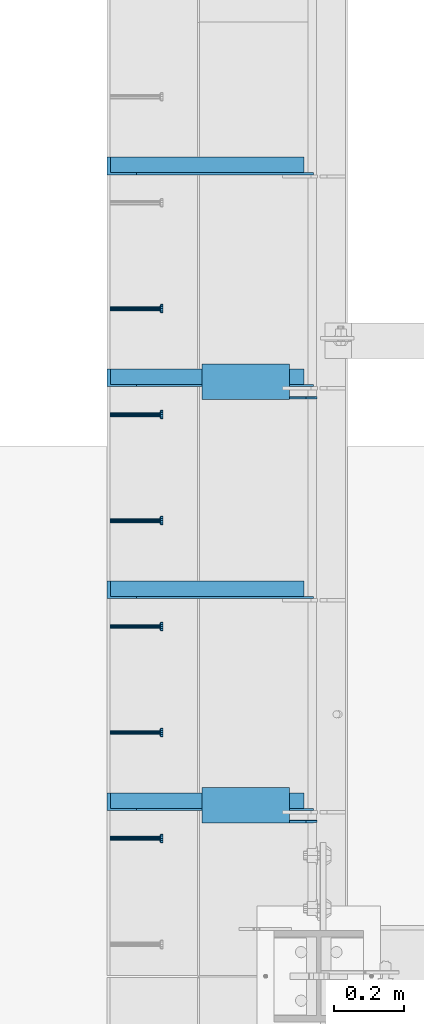
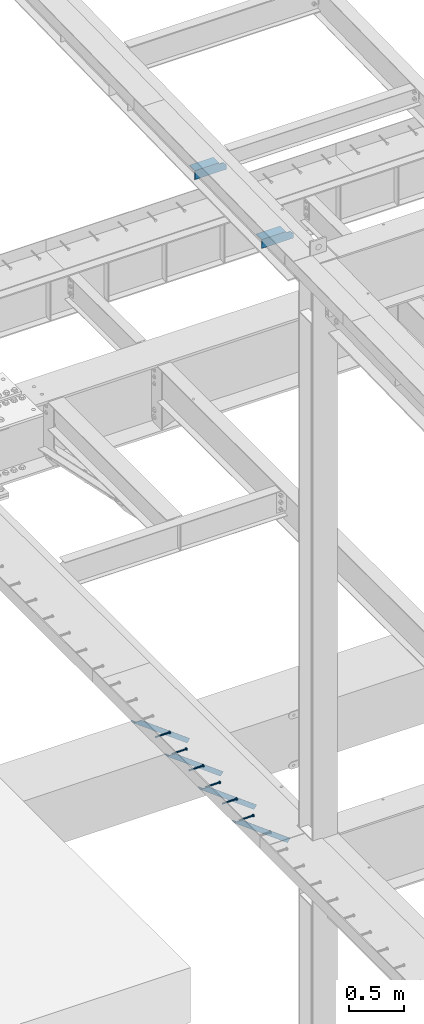
# One storey, part 1329 of 1763: 8 beams, 4 members, 8 elements without a shape of their own.
"""IFC2X3 building model written with IfcOpenShell, lengths in millimetres."""

from ifc_helpers import new_model, si_unit, frame, origin_with_axes, place, context, subcontext, project, spatial, faceted_brep, material, type_object, element, aggregate, save


model = new_model("IFC2X3")

# Units and contexts
model_context = context("Model", 3, precision=1e-05, world=origin_with_axes())
body_context = subcontext(model_context, "Body", "Model", "MODEL_VIEW")
ifc_project = project(units=[si_unit("LENGTHUNIT", "METRE", prefix="MILLI"), si_unit("AREAUNIT", "SQUARE_METRE"), si_unit("VOLUMEUNIT", "CUBIC_METRE"), si_unit("MASSUNIT", "GRAM", prefix="KILO"), si_unit("TIMEUNIT", "SECOND"), si_unit("PLANEANGLEUNIT", "RADIAN"), si_unit("SOLIDANGLEUNIT", "STERADIAN"), si_unit("THERMODYNAMICTEMPERATUREUNIT", "DEGREE_CELSIUS"), si_unit("LUMINOUSINTENSITYUNIT", "LUMEN")], contexts=[model_context])

# Site, building, storey
site_placement = place(None, origin_with_axes())
site = spatial("IfcSite", under=ifc_project, at=site_placement, CompositionType="ELEMENT")
building_placement = place(site_placement, origin_with_axes())
building = spatial("IfcBuilding", under=site, at=building_placement, Name="Undefined", CompositionType="ELEMENT")
storey_placement = place(building_placement, origin_with_axes())
storey = spatial("IfcBuildingStorey", under=building, at=storey_placement, Name="Undefined", CompositionType="ELEMENT", Elevation=0.0)

# Assembly, beam
assembly_1_placement = place(storey_placement, origin_with_axes())
assembly_1 = element("IfcElementAssembly", 1, at=assembly_1_placement, inside=storey, Name="HEADED STUD ANCHOR", AssemblyPlace="NOTDEFINED", PredefinedType="RIGID_FRAME")
ifc_material_1 = material(Name="STEEL/A108")
beam_type_1 = type_object("IfcBeamType", PredefinedType="NOTDEFINED")
beam_1_placement = place(assembly_1_placement, frame((-87975.5122736983, 45202.4750061035, 5268.91250001202), z_axis=(0.0, 0.0, -1.0), x_axis=(1.0, 0.0, 0.0)))
beam_1 = element("IfcBeam", 2, at=beam_1_placement, type_object=beam_type_1, material=ifc_material_1, Name="HEADED STUD ANCHOR", context=body_context, shape_type="Brep", body=[
    faceted_brep([(0.0, -3.1800000667572, 5.5), (0.0, -5.5, 3.1800000667572), (141.732000000002, -5.5, 3.1800000667572), (141.732000000002, -3.1800000667572, 5.5), (0.0, -6.34999999999491, 1.45519152283669e-11), (141.732000000002, -6.34999990463257, 0.0), (0.0, -5.5, -3.1800000667572), (141.732000000002, -5.5, -3.1800000667572), (0.0, -3.1800000667572, -5.5), (141.732000000002, -3.1800000667572, -5.5), (0.0, 0.0, -6.34999990463257), (141.732000000002, 0.0, -6.34999990463257), (0.0, 3.1800000667572, -5.5), (141.732000000002, 3.1800000667572, -5.5), (0.0, 5.5, -3.1800000667572), (141.732000000002, 5.5, -3.1800000667572), (0.0, 6.34999999999491, -2.91038304567337e-11), (141.732000000002, 6.34999990463257, 0.0), (0.0, 5.5, 3.1800000667572), (141.732000000002, 5.5, 3.1800000667572), (0.0, 3.1800000667572, 5.5), (141.732000000002, 3.1800000667572, 5.5), (0.0, 0.0, 6.34999990463257), (141.732000000002, 0.0, 6.34999990463257), (144.780000000001, -10.9899997711182, 6.34999990463257), (144.780000000001, -6.34000015258789, 10.9899997711182), (144.780000000001, -12.6999998092651, 0.0), (144.780000000001, -10.9899997711182, -6.34999990463257), (144.780000000001, -6.34000015258789, -10.9899997711182), (144.780000000001, 0.0, -12.6899995803833), (144.780000000001, 6.34000015258789, -10.9899997711182), (144.780000000001, 10.9899997711182, -6.34999990463257), (144.780000000001, 12.6999998092651, 0.0), (144.780000000001, 10.9899997711182, 6.34999990463257), (144.780000000001, 6.34000015258789, 10.9899997711182), (144.780000000001, 0.0, 12.6899995803833), (152.400000000001, -10.9899997711182, 6.34999990463257), (152.400000000001, -6.34000015258789, 10.9899997711182), (152.400000000001, -12.6999998092651, 0.0), (152.400000000001, -10.9899997711182, -6.34999990463257), (152.400000000001, -6.34000015258789, -10.9899997711182), (152.400000000001, 0.0, -12.6899995803833), (152.400000000001, 6.34000015258789, -10.9899997711182), (152.400000000001, 10.9899997711182, -6.34999990463257), (152.400000000001, 12.6999998092651, 0.0), (152.400000000001, 10.9899997711182, 6.34999990463257), (152.400000000001, 6.34000015258789, 10.9899997711182), (152.400000000001, 0.0, 12.6899995803833)], [[[0, 1, 2, 3]], [[1, 4, 5, 2]], [[4, 6, 7, 5]], [[6, 8, 9, 7]], [[8, 10, 11, 9]], [[10, 12, 13, 11]], [[12, 14, 15, 13]], [[14, 16, 17, 15]], [[16, 18, 19, 17]], [[18, 20, 21, 19]], [[20, 22, 23, 21]], [[22, 0, 3, 23]], [[22, 20, 18, 16, 14, 12, 10, 8, 6, 4, 1, 0]], [[3, 2, 24, 25]], [[2, 5, 26, 24]], [[5, 7, 27, 26]], [[7, 9, 28, 27]], [[9, 11, 29, 28]], [[11, 13, 30, 29]], [[13, 15, 31, 30]], [[15, 17, 32, 31]], [[17, 19, 33, 32]], [[19, 21, 34, 33]], [[21, 23, 35, 34]], [[23, 3, 25, 35]], [[25, 24, 36, 37]], [[24, 26, 38, 36]], [[26, 27, 39, 38]], [[27, 28, 40, 39]], [[28, 29, 41, 40]], [[29, 30, 42, 41]], [[30, 31, 43, 42]], [[31, 32, 44, 43]], [[32, 33, 45, 44]], [[33, 34, 46, 45]], [[34, 35, 47, 46]], [[35, 25, 37, 47]], [[38, 39, 40, 41, 42, 43, 44, 45, 46, 47, 37, 36]]]),
])
aggregate(assembly_1, [beam_1])

assembly_2_placement = place(storey_placement, origin_with_axes())
assembly_2 = element("IfcElementAssembly", 3, at=assembly_2_placement, inside=storey, Name="HEADED STUD ANCHOR", AssemblyPlace="NOTDEFINED", PredefinedType="RIGID_FRAME")
beam_2_placement = place(assembly_2_placement, frame((-87975.5122736983, 45507.2750061035, 5268.91250001202), z_axis=(0.0, 0.0, -1.0), x_axis=(1.0, 0.0, 0.0)))
beam_2 = element("IfcBeam", 4, at=beam_2_placement, type_object=beam_type_1, material=ifc_material_1, Name="HEADED STUD ANCHOR", context=body_context, shape_type="Brep", body=[
    faceted_brep([(0.0, -3.1800000667572, 5.5), (0.0, -5.5, 3.1800000667572), (141.732000000002, -5.5, 3.1800000667572), (141.732000000002, -3.1800000667572, 5.5), (0.0, -6.34999999999491, 1.45519152283669e-11), (141.732000000002, -6.34999990463257, 0.0), (0.0, -5.5, -3.1800000667572), (141.732000000002, -5.5, -3.1800000667572), (0.0, -3.1800000667572, -5.5), (141.732000000002, -3.1800000667572, -5.5), (0.0, 0.0, -6.34999990463257), (141.732000000002, 0.0, -6.34999990463257), (0.0, 3.1800000667572, -5.5), (141.732000000002, 3.1800000667572, -5.5), (0.0, 5.5, -3.1800000667572), (141.732000000002, 5.5, -3.1800000667572), (0.0, 6.34999999999491, -2.91038304567337e-11), (141.732000000002, 6.34999990463257, 0.0), (0.0, 5.5, 3.1800000667572), (141.732000000002, 5.5, 3.1800000667572), (0.0, 3.1800000667572, 5.5), (141.732000000002, 3.1800000667572, 5.5), (0.0, 0.0, 6.34999990463257), (141.732000000002, 0.0, 6.34999990463257), (144.780000000001, -10.9899997711182, 6.34999990463257), (144.780000000001, -6.34000015258789, 10.9899997711182), (144.780000000001, -12.6999998092651, 0.0), (144.780000000001, -10.9899997711182, -6.34999990463257), (144.780000000001, -6.34000015258789, -10.9899997711182), (144.780000000001, 0.0, -12.6899995803833), (144.780000000001, 6.34000015258789, -10.9899997711182), (144.780000000001, 10.9899997711182, -6.34999990463257), (144.780000000001, 12.6999998092651, 0.0), (144.780000000001, 10.9899997711182, 6.34999990463257), (144.780000000001, 6.34000015258789, 10.9899997711182), (144.780000000001, 0.0, 12.6899995803833), (152.400000000001, -10.9899997711182, 6.34999990463257), (152.400000000001, -6.34000015258789, 10.9899997711182), (152.400000000001, -12.6999998092651, 0.0), (152.400000000001, -10.9899997711182, -6.34999990463257), (152.400000000001, -6.34000015258789, -10.9899997711182), (152.400000000001, 0.0, -12.6899995803833), (152.400000000001, 6.34000015258789, -10.9899997711182), (152.400000000001, 10.9899997711182, -6.34999990463257), (152.400000000001, 12.6999998092651, 0.0), (152.400000000001, 10.9899997711182, 6.34999990463257), (152.400000000001, 6.34000015258789, 10.9899997711182), (152.400000000001, 0.0, 12.6899995803833)], [[[0, 1, 2, 3]], [[1, 4, 5, 2]], [[4, 6, 7, 5]], [[6, 8, 9, 7]], [[8, 10, 11, 9]], [[10, 12, 13, 11]], [[12, 14, 15, 13]], [[14, 16, 17, 15]], [[16, 18, 19, 17]], [[18, 20, 21, 19]], [[20, 22, 23, 21]], [[22, 0, 3, 23]], [[22, 20, 18, 16, 14, 12, 10, 8, 6, 4, 1, 0]], [[3, 2, 24, 25]], [[2, 5, 26, 24]], [[5, 7, 27, 26]], [[7, 9, 28, 27]], [[9, 11, 29, 28]], [[11, 13, 30, 29]], [[13, 15, 31, 30]], [[15, 17, 32, 31]], [[17, 19, 33, 32]], [[19, 21, 34, 33]], [[21, 23, 35, 34]], [[23, 3, 25, 35]], [[25, 24, 36, 37]], [[24, 26, 38, 36]], [[26, 27, 39, 38]], [[27, 28, 40, 39]], [[28, 29, 41, 40]], [[29, 30, 42, 41]], [[30, 31, 43, 42]], [[31, 32, 44, 43]], [[32, 33, 45, 44]], [[33, 34, 46, 45]], [[34, 35, 47, 46]], [[35, 25, 37, 47]], [[38, 39, 40, 41, 42, 43, 44, 45, 46, 47, 37, 36]]]),
])
aggregate(assembly_2, [beam_2])

assembly_3_placement = place(storey_placement, origin_with_axes())
assembly_3 = element("IfcElementAssembly", 5, at=assembly_3_placement, inside=storey, Name="HEADED STUD ANCHOR", AssemblyPlace="NOTDEFINED", PredefinedType="RIGID_FRAME")
beam_3_placement = place(assembly_3_placement, frame((-87975.5122736983, 45812.0750061035, 5268.91250001202), z_axis=(0.0, 0.0, -1.0), x_axis=(1.0, 0.0, 0.0)))
beam_3 = element("IfcBeam", 6, at=beam_3_placement, type_object=beam_type_1, material=ifc_material_1, Name="HEADED STUD ANCHOR", context=body_context, shape_type="Brep", body=[
    faceted_brep([(0.0, -3.1800000667572, 5.5), (0.0, -5.5, 3.1800000667572), (141.732000000002, -5.5, 3.1800000667572), (141.732000000002, -3.1800000667572, 5.5), (0.0, -6.34999999999491, 1.45519152283669e-11), (141.732000000002, -6.34999990463257, 0.0), (0.0, -5.5, -3.1800000667572), (141.732000000002, -5.5, -3.1800000667572), (0.0, -3.1800000667572, -5.5), (141.732000000002, -3.1800000667572, -5.5), (0.0, 0.0, -6.34999990463257), (141.732000000002, 0.0, -6.34999990463257), (0.0, 3.1800000667572, -5.5), (141.732000000002, 3.1800000667572, -5.5), (0.0, 5.5, -3.1800000667572), (141.732000000002, 5.5, -3.1800000667572), (0.0, 6.34999999999491, -2.91038304567337e-11), (141.732000000002, 6.34999990463257, 0.0), (0.0, 5.5, 3.1800000667572), (141.732000000002, 5.5, 3.1800000667572), (0.0, 3.1800000667572, 5.5), (141.732000000002, 3.1800000667572, 5.5), (0.0, 0.0, 6.34999990463257), (141.732000000002, 0.0, 6.34999990463257), (144.780000000001, -10.9899997711182, 6.34999990463257), (144.780000000001, -6.34000015258789, 10.9899997711182), (144.780000000001, -12.6999998092651, 0.0), (144.780000000001, -10.9899997711182, -6.34999990463257), (144.780000000001, -6.34000015258789, -10.9899997711182), (144.780000000001, 0.0, -12.6899995803833), (144.780000000001, 6.34000015258789, -10.9899997711182), (144.780000000001, 10.9899997711182, -6.34999990463257), (144.780000000001, 12.6999998092651, 0.0), (144.780000000001, 10.9899997711182, 6.34999990463257), (144.780000000001, 6.34000015258789, 10.9899997711182), (144.780000000001, 0.0, 12.6899995803833), (152.400000000001, -10.9899997711182, 6.34999990463257), (152.400000000001, -6.34000015258789, 10.9899997711182), (152.400000000001, -12.6999998092651, 0.0), (152.400000000001, -10.9899997711182, -6.34999990463257), (152.400000000001, -6.34000015258789, -10.9899997711182), (152.400000000001, 0.0, -12.6899995803833), (152.400000000001, 6.34000015258789, -10.9899997711182), (152.400000000001, 10.9899997711182, -6.34999990463257), (152.400000000001, 12.6999998092651, 0.0), (152.400000000001, 10.9899997711182, 6.34999990463257), (152.400000000001, 6.34000015258789, 10.9899997711182), (152.400000000001, 0.0, 12.6899995803833)], [[[0, 1, 2, 3]], [[1, 4, 5, 2]], [[4, 6, 7, 5]], [[6, 8, 9, 7]], [[8, 10, 11, 9]], [[10, 12, 13, 11]], [[12, 14, 15, 13]], [[14, 16, 17, 15]], [[16, 18, 19, 17]], [[18, 20, 21, 19]], [[20, 22, 23, 21]], [[22, 0, 3, 23]], [[22, 20, 18, 16, 14, 12, 10, 8, 6, 4, 1, 0]], [[3, 2, 24, 25]], [[2, 5, 26, 24]], [[5, 7, 27, 26]], [[7, 9, 28, 27]], [[9, 11, 29, 28]], [[11, 13, 30, 29]], [[13, 15, 31, 30]], [[15, 17, 32, 31]], [[17, 19, 33, 32]], [[19, 21, 34, 33]], [[21, 23, 35, 34]], [[23, 3, 25, 35]], [[25, 24, 36, 37]], [[24, 26, 38, 36]], [[26, 27, 39, 38]], [[27, 28, 40, 39]], [[28, 29, 41, 40]], [[29, 30, 42, 41]], [[30, 31, 43, 42]], [[31, 32, 44, 43]], [[32, 33, 45, 44]], [[33, 34, 46, 45]], [[34, 35, 47, 46]], [[35, 25, 37, 47]], [[38, 39, 40, 41, 42, 43, 44, 45, 46, 47, 37, 36]]]),
])
aggregate(assembly_3, [beam_3])

assembly_4_placement = place(storey_placement, origin_with_axes())
assembly_4 = element("IfcElementAssembly", 7, at=assembly_4_placement, inside=storey, Name="HEADED STUD ANCHOR", AssemblyPlace="NOTDEFINED", PredefinedType="RIGID_FRAME")
beam_4_placement = place(assembly_4_placement, frame((-87975.5122736983, 46116.8750061035, 5268.91250001202), z_axis=(0.0, 0.0, -1.0), x_axis=(1.0, 0.0, 0.0)))
beam_4 = element("IfcBeam", 8, at=beam_4_placement, type_object=beam_type_1, material=ifc_material_1, Name="HEADED STUD ANCHOR", context=body_context, shape_type="Brep", body=[
    faceted_brep([(0.0, -3.1800000667572, 5.5), (0.0, -5.5, 3.1800000667572), (141.732000000002, -5.5, 3.1800000667572), (141.732000000002, -3.1800000667572, 5.5), (0.0, -6.34999999999491, 1.45519152283669e-11), (141.732000000002, -6.34999990463257, 0.0), (0.0, -5.5, -3.1800000667572), (141.732000000002, -5.5, -3.1800000667572), (0.0, -3.1800000667572, -5.5), (141.732000000002, -3.1800000667572, -5.5), (0.0, 0.0, -6.34999990463257), (141.732000000002, 0.0, -6.34999990463257), (0.0, 3.1800000667572, -5.5), (141.732000000002, 3.1800000667572, -5.5), (0.0, 5.5, -3.1800000667572), (141.732000000002, 5.5, -3.1800000667572), (0.0, 6.34999999999491, -2.91038304567337e-11), (141.732000000002, 6.34999990463257, 0.0), (0.0, 5.5, 3.1800000667572), (141.732000000002, 5.5, 3.1800000667572), (0.0, 3.1800000667572, 5.5), (141.732000000002, 3.1800000667572, 5.5), (0.0, 0.0, 6.34999990463257), (141.732000000002, 0.0, 6.34999990463257), (144.780000000001, -10.9899997711182, 6.34999990463257), (144.780000000001, -6.34000015258789, 10.9899997711182), (144.780000000001, -12.6999998092651, 0.0), (144.780000000001, -10.9899997711182, -6.34999990463257), (144.780000000001, -6.34000015258789, -10.9899997711182), (144.780000000001, 0.0, -12.6899995803833), (144.780000000001, 6.34000015258789, -10.9899997711182), (144.780000000001, 10.9899997711182, -6.34999990463257), (144.780000000001, 12.6999998092651, 0.0), (144.780000000001, 10.9899997711182, 6.34999990463257), (144.780000000001, 6.34000015258789, 10.9899997711182), (144.780000000001, 0.0, 12.6899995803833), (152.400000000001, -10.9899997711182, 6.34999990463257), (152.400000000001, -6.34000015258789, 10.9899997711182), (152.400000000001, -12.6999998092651, 0.0), (152.400000000001, -10.9899997711182, -6.34999990463257), (152.400000000001, -6.34000015258789, -10.9899997711182), (152.400000000001, 0.0, -12.6899995803833), (152.400000000001, 6.34000015258789, -10.9899997711182), (152.400000000001, 10.9899997711182, -6.34999990463257), (152.400000000001, 12.6999998092651, 0.0), (152.400000000001, 10.9899997711182, 6.34999990463257), (152.400000000001, 6.34000015258789, 10.9899997711182), (152.400000000001, 0.0, 12.6899995803833)], [[[0, 1, 2, 3]], [[1, 4, 5, 2]], [[4, 6, 7, 5]], [[6, 8, 9, 7]], [[8, 10, 11, 9]], [[10, 12, 13, 11]], [[12, 14, 15, 13]], [[14, 16, 17, 15]], [[16, 18, 19, 17]], [[18, 20, 21, 19]], [[20, 22, 23, 21]], [[22, 0, 3, 23]], [[22, 20, 18, 16, 14, 12, 10, 8, 6, 4, 1, 0]], [[3, 2, 24, 25]], [[2, 5, 26, 24]], [[5, 7, 27, 26]], [[7, 9, 28, 27]], [[9, 11, 29, 28]], [[11, 13, 30, 29]], [[13, 15, 31, 30]], [[15, 17, 32, 31]], [[17, 19, 33, 32]], [[19, 21, 34, 33]], [[21, 23, 35, 34]], [[23, 3, 25, 35]], [[25, 24, 36, 37]], [[24, 26, 38, 36]], [[26, 27, 39, 38]], [[27, 28, 40, 39]], [[28, 29, 41, 40]], [[29, 30, 42, 41]], [[30, 31, 43, 42]], [[31, 32, 44, 43]], [[32, 33, 45, 44]], [[33, 34, 46, 45]], [[34, 35, 47, 46]], [[35, 25, 37, 47]], [[38, 39, 40, 41, 42, 43, 44, 45, 46, 47, 37, 36]]]),
])
aggregate(assembly_4, [beam_4])

assembly_5_placement = place(storey_placement, origin_with_axes())
assembly_5 = element("IfcElementAssembly", 9, at=assembly_5_placement, inside=storey, Name="HEADED STUD ANCHOR", AssemblyPlace="NOTDEFINED", PredefinedType="RIGID_FRAME")
beam_5_placement = place(assembly_5_placement, frame((-87975.5122736983, 46421.6750061035, 5268.91250001202), z_axis=(0.0, 0.0, -1.0), x_axis=(1.0, 0.0, 0.0)))
beam_5 = element("IfcBeam", 10, at=beam_5_placement, type_object=beam_type_1, material=ifc_material_1, Name="HEADED STUD ANCHOR", context=body_context, shape_type="Brep", body=[
    faceted_brep([(0.0, -3.1800000667572, 5.5), (0.0, -5.5, 3.1800000667572), (141.732000000002, -5.5, 3.1800000667572), (141.732000000002, -3.1800000667572, 5.5), (0.0, -6.34999999999491, 1.45519152283669e-11), (141.732000000002, -6.34999990463257, 0.0), (0.0, -5.5, -3.1800000667572), (141.732000000002, -5.5, -3.1800000667572), (0.0, -3.1800000667572, -5.5), (141.732000000002, -3.1800000667572, -5.5), (0.0, 0.0, -6.34999990463257), (141.732000000002, 0.0, -6.34999990463257), (0.0, 3.1800000667572, -5.5), (141.732000000002, 3.1800000667572, -5.5), (0.0, 5.5, -3.1800000667572), (141.732000000002, 5.5, -3.1800000667572), (0.0, 6.34999999999491, -2.91038304567337e-11), (141.732000000002, 6.34999990463257, 0.0), (0.0, 5.5, 3.1800000667572), (141.732000000002, 5.5, 3.1800000667572), (0.0, 3.1800000667572, 5.5), (141.732000000002, 3.1800000667572, 5.5), (0.0, 0.0, 6.34999990463257), (141.732000000002, 0.0, 6.34999990463257), (144.780000000001, -10.9899997711182, 6.34999990463257), (144.780000000001, -6.34000015258789, 10.9899997711182), (144.780000000001, -12.6999998092651, 0.0), (144.780000000001, -10.9899997711182, -6.34999990463257), (144.780000000001, -6.34000015258789, -10.9899997711182), (144.780000000001, 0.0, -12.6899995803833), (144.780000000001, 6.34000015258789, -10.9899997711182), (144.780000000001, 10.9899997711182, -6.34999990463257), (144.780000000001, 12.6999998092651, 0.0), (144.780000000001, 10.9899997711182, 6.34999990463257), (144.780000000001, 6.34000015258789, 10.9899997711182), (144.780000000001, 0.0, 12.6899995803833), (152.400000000001, -10.9899997711182, 6.34999990463257), (152.400000000001, -6.34000015258789, 10.9899997711182), (152.400000000001, -12.6999998092651, 0.0), (152.400000000001, -10.9899997711182, -6.34999990463257), (152.400000000001, -6.34000015258789, -10.9899997711182), (152.400000000001, 0.0, -12.6899995803833), (152.400000000001, 6.34000015258789, -10.9899997711182), (152.400000000001, 10.9899997711182, -6.34999990463257), (152.400000000001, 12.6999998092651, 0.0), (152.400000000001, 10.9899997711182, 6.34999990463257), (152.400000000001, 6.34000015258789, 10.9899997711182), (152.400000000001, 0.0, 12.6899995803833)], [[[0, 1, 2, 3]], [[1, 4, 5, 2]], [[4, 6, 7, 5]], [[6, 8, 9, 7]], [[8, 10, 11, 9]], [[10, 12, 13, 11]], [[12, 14, 15, 13]], [[14, 16, 17, 15]], [[16, 18, 19, 17]], [[18, 20, 21, 19]], [[20, 22, 23, 21]], [[22, 0, 3, 23]], [[22, 20, 18, 16, 14, 12, 10, 8, 6, 4, 1, 0]], [[3, 2, 24, 25]], [[2, 5, 26, 24]], [[5, 7, 27, 26]], [[7, 9, 28, 27]], [[9, 11, 29, 28]], [[11, 13, 30, 29]], [[13, 15, 31, 30]], [[15, 17, 32, 31]], [[17, 19, 33, 32]], [[19, 21, 34, 33]], [[21, 23, 35, 34]], [[23, 3, 25, 35]], [[25, 24, 36, 37]], [[24, 26, 38, 36]], [[26, 27, 39, 38]], [[27, 28, 40, 39]], [[28, 29, 41, 40]], [[29, 30, 42, 41]], [[30, 31, 43, 42]], [[31, 32, 44, 43]], [[32, 33, 45, 44]], [[33, 34, 46, 45]], [[34, 35, 47, 46]], [[35, 25, 37, 47]], [[38, 39, 40, 41, 42, 43, 44, 45, 46, 47, 37, 36]]]),
])
aggregate(assembly_5, [beam_5])

assembly_6_placement = place(storey_placement, origin_with_axes())
assembly_6 = element("IfcElementAssembly", 11, at=assembly_6_placement, inside=storey, Name="HEADED STUD ANCHOR", AssemblyPlace="NOTDEFINED", PredefinedType="RIGID_FRAME")
beam_6_placement = place(assembly_6_placement, frame((-87975.5122736983, 46726.4750061035, 5268.91250001202), z_axis=(0.0, 0.0, -1.0), x_axis=(1.0, 0.0, 0.0)))
beam_6 = element("IfcBeam", 12, at=beam_6_placement, type_object=beam_type_1, material=ifc_material_1, Name="HEADED STUD ANCHOR", context=body_context, shape_type="Brep", body=[
    faceted_brep([(0.0, -3.1800000667572, 5.5), (0.0, -5.5, 3.1800000667572), (141.732000000002, -5.5, 3.1800000667572), (141.732000000002, -3.1800000667572, 5.5), (0.0, -6.34999999999491, 1.45519152283669e-11), (141.732000000002, -6.34999990463257, 0.0), (0.0, -5.5, -3.1800000667572), (141.732000000002, -5.5, -3.1800000667572), (0.0, -3.1800000667572, -5.5), (141.732000000002, -3.1800000667572, -5.5), (0.0, 0.0, -6.34999990463257), (141.732000000002, 0.0, -6.34999990463257), (0.0, 3.1800000667572, -5.5), (141.732000000002, 3.1800000667572, -5.5), (0.0, 5.5, -3.1800000667572), (141.732000000002, 5.5, -3.1800000667572), (0.0, 6.34999999999491, -2.91038304567337e-11), (141.732000000002, 6.34999990463257, 0.0), (0.0, 5.5, 3.1800000667572), (141.732000000002, 5.5, 3.1800000667572), (0.0, 3.1800000667572, 5.5), (141.732000000002, 3.1800000667572, 5.5), (0.0, 0.0, 6.34999990463257), (141.732000000002, 0.0, 6.34999990463257), (144.780000000001, -10.9899997711182, 6.34999990463257), (144.780000000001, -6.34000015258789, 10.9899997711182), (144.780000000001, -12.6999998092651, 0.0), (144.780000000001, -10.9899997711182, -6.34999990463257), (144.780000000001, -6.34000015258789, -10.9899997711182), (144.780000000001, 0.0, -12.6899995803833), (144.780000000001, 6.34000015258789, -10.9899997711182), (144.780000000001, 10.9899997711182, -6.34999990463257), (144.780000000001, 12.6999998092651, 0.0), (144.780000000001, 10.9899997711182, 6.34999990463257), (144.780000000001, 6.34000015258789, 10.9899997711182), (144.780000000001, 0.0, 12.6899995803833), (152.400000000001, -10.9899997711182, 6.34999990463257), (152.400000000001, -6.34000015258789, 10.9899997711182), (152.400000000001, -12.6999998092651, 0.0), (152.400000000001, -10.9899997711182, -6.34999990463257), (152.400000000001, -6.34000015258789, -10.9899997711182), (152.400000000001, 0.0, -12.6899995803833), (152.400000000001, 6.34000015258789, -10.9899997711182), (152.400000000001, 10.9899997711182, -6.34999990463257), (152.400000000001, 12.6999998092651, 0.0), (152.400000000001, 10.9899997711182, 6.34999990463257), (152.400000000001, 6.34000015258789, 10.9899997711182), (152.400000000001, 0.0, 12.6899995803833)], [[[0, 1, 2, 3]], [[1, 4, 5, 2]], [[4, 6, 7, 5]], [[6, 8, 9, 7]], [[8, 10, 11, 9]], [[10, 12, 13, 11]], [[12, 14, 15, 13]], [[14, 16, 17, 15]], [[16, 18, 19, 17]], [[18, 20, 21, 19]], [[20, 22, 23, 21]], [[22, 0, 3, 23]], [[22, 20, 18, 16, 14, 12, 10, 8, 6, 4, 1, 0]], [[3, 2, 24, 25]], [[2, 5, 26, 24]], [[5, 7, 27, 26]], [[7, 9, 28, 27]], [[9, 11, 29, 28]], [[11, 13, 30, 29]], [[13, 15, 31, 30]], [[15, 17, 32, 31]], [[17, 19, 33, 32]], [[19, 21, 34, 33]], [[21, 23, 35, 34]], [[23, 3, 25, 35]], [[25, 24, 36, 37]], [[24, 26, 38, 36]], [[26, 27, 39, 38]], [[27, 28, 40, 39]], [[28, 29, 41, 40]], [[29, 30, 42, 41]], [[30, 31, 43, 42]], [[31, 32, 44, 43]], [[32, 33, 45, 44]], [[33, 34, 46, 45]], [[34, 35, 47, 46]], [[35, 25, 37, 47]], [[38, 39, 40, 41, 42, 43, 44, 45, 46, 47, 37, 36]]]),
])
aggregate(assembly_6, [beam_6])

# Assembly, members
assembly_7_placement = place(storey_placement, origin_with_axes())
assembly_7 = element("IfcElementAssembly", 13, at=assembly_7_placement, inside=storey, Name="BEAM", AssemblyPlace="NOTDEFINED", PredefinedType="RIGID_FRAME")
ifc_material_2 = material(Name="STEEL/A36")
member_type = type_object("IfcMemberType", Name="L2X2X1/4", PredefinedType="NOTDEFINED")
member_1_placement = place(assembly_7_placement, frame((-87406.0995933455, 45917.64375, 4794.78284113776), z_axis=(0.597323303215295, 0.0, 0.802000543289074), x_axis=(-0.802000543289071, 0.0, 0.597323303215297)))
member_1 = element("IfcMember", 14, at=member_1_placement, type_object=member_type, material=ifc_material_2, Name="ANGLE", ObjectType="L2X2X1/4", context=body_context, shape_type="Brep", body=[
    faceted_brep([(-1.45519152283669e-11, 25.4000000000015, -25.3999999999869), (1.45519152283669e-11, 25.4000000000015, 25.3999999999796), (634.74226311341, 25.4000000000015, 25.3999999990119), (702.949257616929, 25.4000000000015, -25.4000000010055), (1.45519152283669e-11, 19.0499999999993, 25.3999999999796), (634.74226311341, 19.0500000000029, 25.3999999990119), (-7.27595761418343e-12, 19.0499999999993, -19.0499999999956), (694.423383303991, 19.0500000000029, -19.050000001007), (-7.27595761418343e-12, -25.4000000000015, -19.0499999999956), (694.423383303991, -25.4000000000015, -19.050000001007), (-1.45519152283669e-11, -25.4000000000015, -25.3999999999869), (702.949257616929, -25.4000000000015, -25.4000000010055)], [[[0, 1, 2, 3]], [[1, 4, 5, 2]], [[4, 6, 7, 5]], [[6, 8, 9, 7]], [[8, 10, 11, 9]], [[10, 0, 3, 11]], [[5, 7, 9, 11, 3, 2]], [[10, 8, 6, 4, 1, 0]]]),
])
member_2_placement = place(assembly_7_placement, frame((-87406.0995933455, 47136.84375, 4794.78284113776), z_axis=(0.597323303215295, 0.0, 0.802000543289074), x_axis=(-0.802000543289071, 0.0, 0.597323303215297)))
member_2 = element("IfcMember", 15, at=member_2_placement, type_object=member_type, material=ifc_material_2, Name="ANGLE", ObjectType="L2X2X1/4", context=body_context, shape_type="Brep", body=[
    faceted_brep([(-1.45519152283669e-11, 25.4000000000015, -25.3999999999869), (1.45519152283669e-11, 25.4000000000015, 25.3999999999796), (634.74226311341, 25.4000000000015, 25.3999999990119), (702.949257616929, 25.4000000000015, -25.4000000010055), (1.45519152283669e-11, 19.0499999999993, 25.3999999999796), (634.74226311341, 19.0500000000029, 25.3999999990119), (-7.27595761418343e-12, 19.0499999999993, -19.0499999999956), (694.423383303991, 19.0500000000029, -19.050000001007), (-7.27595761418343e-12, -25.4000000000015, -19.0499999999956), (694.423383303991, -25.4000000000015, -19.050000001007), (-1.45519152283669e-11, -25.4000000000015, -25.3999999999869), (702.949257616929, -25.4000000000015, -25.4000000010055)], [[[0, 1, 2, 3]], [[1, 4, 5, 2]], [[4, 6, 7, 5]], [[6, 8, 9, 7]], [[8, 10, 11, 9]], [[10, 0, 3, 11]], [[5, 7, 9, 11, 3, 2]], [[10, 8, 6, 4, 1, 0]]]),
])
member_3_placement = place(assembly_7_placement, frame((-87406.0995933455, 45308.04375, 4794.78284113776), z_axis=(0.597323303215295, 0.0, 0.802000543289074), x_axis=(-0.802000543289071, 0.0, 0.597323303215297)))
member_3 = element("IfcMember", 16, at=member_3_placement, type_object=member_type, material=ifc_material_2, Name="ANGLE", ObjectType="L2X2X1/4", context=body_context, shape_type="Brep", body=[
    faceted_brep([(-1.45519152283669e-11, 25.4000000000015, -25.3999999999869), (1.45519152283669e-11, 25.4000000000015, 25.3999999999796), (634.74226311341, 25.4000000000015, 25.3999999990119), (702.949257616929, 25.4000000000015, -25.4000000010055), (1.45519152283669e-11, 19.0499999999993, 25.3999999999796), (634.74226311341, 19.0500000000029, 25.3999999990119), (-7.27595761418343e-12, 19.0499999999993, -19.0499999999956), (694.423383303991, 19.0500000000029, -19.050000001007), (-7.27595761418343e-12, -25.4000000000015, -19.0499999999956), (694.423383303991, -25.4000000000015, -19.050000001007), (-1.45519152283669e-11, -25.4000000000015, -25.3999999999869), (702.949257616929, -25.4000000000015, -25.4000000010055)], [[[0, 1, 2, 3]], [[1, 4, 5, 2]], [[4, 6, 7, 5]], [[6, 8, 9, 7]], [[8, 10, 11, 9]], [[10, 0, 3, 11]], [[5, 7, 9, 11, 3, 2]], [[10, 8, 6, 4, 1, 0]]]),
])
member_4_placement = place(assembly_7_placement, frame((-87406.0995933455, 46527.24375, 4794.78284113776), z_axis=(0.597323303215295, 0.0, 0.802000543289074), x_axis=(-0.802000543289071, 0.0, 0.597323303215297)))
member_4 = element("IfcMember", 17, at=member_4_placement, type_object=member_type, material=ifc_material_2, Name="ANGLE", ObjectType="L2X2X1/4", context=body_context, shape_type="Brep", body=[
    faceted_brep([(-1.45519152283669e-11, 25.4000000000015, -25.3999999999869), (1.45519152283669e-11, 25.4000000000015, 25.3999999999796), (634.74226311341, 25.4000000000015, 25.3999999990119), (702.949257616929, 25.4000000000015, -25.4000000010055), (1.45519152283669e-11, 19.0499999999993, 25.3999999999796), (634.74226311341, 19.0500000000029, 25.3999999990119), (-7.27595761418343e-12, 19.0499999999993, -19.0499999999956), (694.423383303991, 19.0500000000029, -19.050000001007), (-7.27595761418343e-12, -25.4000000000015, -19.0499999999956), (694.423383303991, -25.4000000000015, -19.050000001007), (-1.45519152283669e-11, -25.4000000000015, -25.3999999999869), (702.949257616929, -25.4000000000015, -25.4000000010055)], [[[0, 1, 2, 3]], [[1, 4, 5, 2]], [[4, 6, 7, 5]], [[6, 8, 9, 7]], [[8, 10, 11, 9]], [[10, 0, 3, 11]], [[5, 7, 9, 11, 3, 2]], [[10, 8, 6, 4, 1, 0]]]),
])
aggregate(assembly_7, [member_1, member_2, member_3, member_4])

# Assembly, beams
assembly_8_placement = place(storey_placement, origin_with_axes())
assembly_8 = element("IfcElementAssembly", 18, at=assembly_8_placement, inside=storey, Name="BEAM", AssemblyPlace="NOTDEFINED", PredefinedType="RIGID_FRAME")
beam_type_2 = type_object("IfcBeamType", Name="L4X4X1/4", PredefinedType="NOTDEFINED")
beam_7_placement = place(assembly_8_placement, frame((-87711.9872706467, 46517.6459540349, 11580.7617971513), z_axis=(0.0, 0.0206852279954837, -0.999786037781472), x_axis=(1.0, 0.0, 0.0)))
beam_7 = element("IfcBeam", 19, at=beam_7_placement, type_object=beam_type_2, material=ifc_material_2, Name="BRACE", ObjectType="L4X4X1/4", context=body_context, shape_type="Brep", body=[
    faceted_brep([(252.412491188385, 44.4500000001135, -44.4499999999807), (252.412491263516, -50.800000000163, -44.4499999999534), (252.412497029261, -50.800000000163, -50.7999999999502), (252.41249694943, 50.8000000001412, -50.7999999999756), (252.41248397647, 50.8000000001339, -36.5124986658775), (252.412483981447, 44.4500000001135, -36.5124986595329), (300.037533980634, 44.4500000001208, -36.5124999853924), (300.037533980634, 50.8000000001339, -36.5124999853942), (2.11002770811319e-10, -50.8000000000357, -50.799999999952), (1.96450855582952e-10, -50.8000000000338, -44.4499999999534), (-2.18278728425503e-11, 44.4500000000007, -44.450000000048), (-1.81898940354586e-10, 44.4500000000371, 50.7999999999374), (-1.96450855582952e-10, 50.8000000000393, 50.7999999999374), (-3.63797880709171e-11, 50.8000000000011, -50.8000000000538), (331.787546948486, 44.4500000001353, 50.7999999999502), (331.787546948486, 50.8000000001557, 50.7999999999465), (331.787533980634, 44.4500000001281, -4.76249998546336), (331.787546948486, 50.8000000001412, -4.76249998546518)], [[[0, 1, 2, 3, 4, 5]], [[6, 5, 4, 7]], [[8, 9, 10, 11, 12, 13]], [[12, 11, 14, 15]], [[15, 14, 16, 17]], [[17, 16, 6, 7]], [[3, 13, 12, 15, 17, 7, 4]], [[8, 13, 3, 2]], [[9, 8, 2, 1]], [[10, 9, 1, 0]], [[16, 14, 11, 10, 0, 5, 6]]]),
])
beam_8_placement = place(assembly_8_placement, frame((-87711.9872706469, 45298.7068167717, 11555.5423671794), z_axis=(0.0, 0.0206852279954837, -0.999786037781472), x_axis=(1.0, 0.0, 0.0)))
beam_8 = element("IfcBeam", 20, at=beam_8_placement, type_object=beam_type_2, material=ifc_material_2, Name="BRACE", ObjectType="L4X4X1/4", context=body_context, shape_type="Brep", body=[
    faceted_brep([(252.412491188385, 44.4500000001135, -44.4499999999807), (252.412491263516, -50.800000000163, -44.4499999999534), (252.412497029261, -50.800000000163, -50.7999999999502), (252.41249694943, 50.8000000001412, -50.7999999999756), (252.41248397647, 50.8000000001339, -36.5124986658775), (252.412483981447, 44.4500000001135, -36.5124986595329), (300.037533980634, 44.4500000001208, -36.5124999853924), (300.037533980634, 50.8000000001339, -36.5124999853942), (2.11002770811319e-10, -50.8000000000357, -50.799999999952), (1.96450855582952e-10, -50.8000000000338, -44.4499999999534), (-2.18278728425503e-11, 44.4500000000007, -44.450000000048), (-1.81898940354586e-10, 44.4500000000371, 50.7999999999374), (-1.96450855582952e-10, 50.8000000000393, 50.7999999999374), (-3.63797880709171e-11, 50.8000000000011, -50.8000000000538), (331.787546948486, 44.4500000001353, 50.7999999999502), (331.787546948486, 50.8000000001557, 50.7999999999465), (331.787533980634, 44.4500000001281, -4.76249998546336), (331.787546948486, 50.8000000001412, -4.76249998546518)], [[[0, 1, 2, 3, 4, 5]], [[6, 5, 4, 7]], [[8, 9, 10, 11, 12, 13]], [[12, 11, 14, 15]], [[15, 14, 16, 17]], [[17, 16, 6, 7]], [[3, 13, 12, 15, 17, 7, 4]], [[8, 13, 3, 2]], [[9, 8, 2, 1]], [[10, 9, 1, 0]], [[16, 14, 11, 10, 0, 5, 6]]]),
])
aggregate(assembly_8, [beam_7, beam_8])

save(model, "model.ifc")
